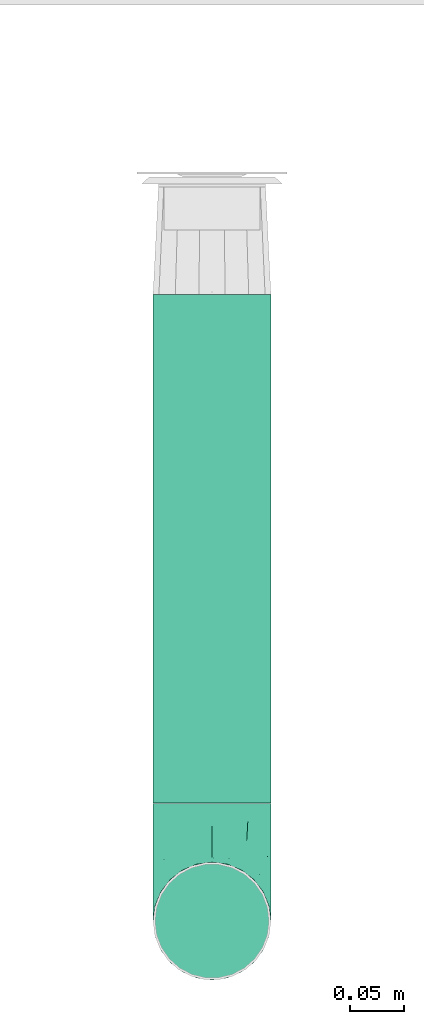
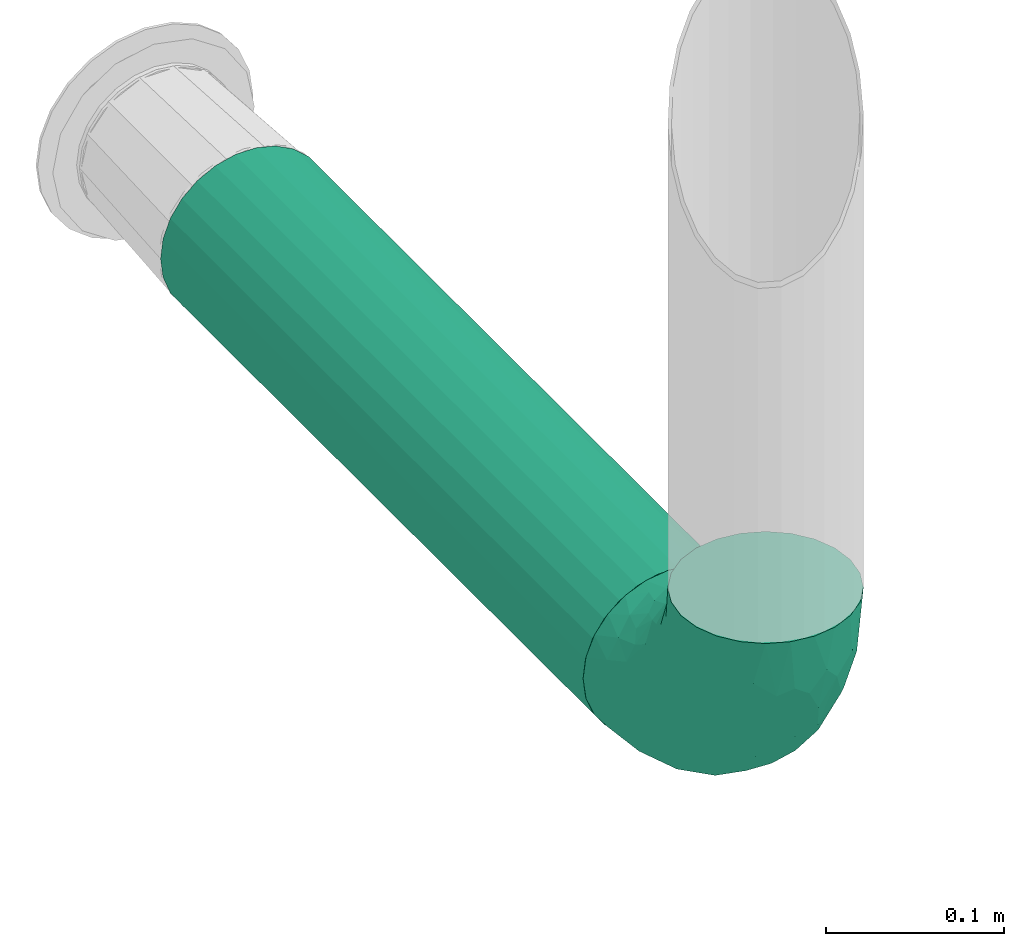
# One storey, part 72 of 123: 1 flow fitting, 1 flow segment.
"""IFC2X3 building model written with IfcOpenShell, lengths in millimetres."""

from ifc_helpers import new_model, entity, si_unit, converted_unit, derived_unit, direction, frame, origin_with_axes, origin_2d_with_axis, place, context, subcontext, project, spatial, hollow_circle, extrude, open_shell, surface_model, source, transform, mapped, material, layer, layer_set, layer_usage, type_object, element, save


model = new_model("IFC2X3")

# Units and contexts
model_context = context("Model", 3, precision=1e-05, world=origin_with_axes(), true_north=direction((0.0, 1.0)))
body_context = subcontext(model_context, "Body", "Model", "MODEL_VIEW")
ifc_project = project(units=[si_unit("AREAUNIT", "SQUARE_METRE"), si_unit("VOLUMEUNIT", "CUBIC_METRE", prefix="DECI"), si_unit("TIMEUNIT", "SECOND"), si_unit("THERMODYNAMICTEMPERATUREUNIT", "DEGREE_CELSIUS"), si_unit("PRESSUREUNIT", "PASCAL"), si_unit("MASSUNIT", "GRAM", prefix="KILO"), si_unit("LENGTHUNIT", "METRE", prefix="MILLI"), si_unit("POWERUNIT", "WATT"), si_unit("ELECTRICCURRENTUNIT", "AMPERE"), si_unit("ELECTRICVOLTAGEUNIT", "VOLT"), derived_unit("VOLUMETRICFLOWRATEUNIT", [(si_unit("VOLUMEUNIT", "CUBIC_METRE", prefix="DECI"), 1), (si_unit("TIMEUNIT", "SECOND"), -1)]), derived_unit("LINEARVELOCITYUNIT", [(si_unit("LENGTHUNIT", "METRE"), 1), (si_unit("TIMEUNIT", "SECOND"), -1)]), derived_unit("MASSDENSITYUNIT", [(si_unit("MASSUNIT", "GRAM", prefix="KILO"), 1), (si_unit("VOLUMEUNIT", "CUBIC_METRE"), -1)]), converted_unit("PLANEANGLEUNIT", "DEGREE", entity("IfcRatioMeasure", 0.01745), si_unit("PLANEANGLEUNIT", "RADIAN"), dimensions=[0, 0, 0, 0, 0, 0, 0])], contexts=[model_context])

# Site, building, storey
site_placement = place(None, origin_with_axes())
site = spatial("IfcSite", under=ifc_project, at=site_placement, CompositionType="ELEMENT")
building_placement = place(site_placement, origin_with_axes())
building = spatial("IfcBuilding", under=site, at=building_placement, Name="mc-building", CompositionType="ELEMENT")
storey_placement = place(building_placement, origin_with_axes())
storey = spatial("IfcBuildingStorey", under=building, at=storey_placement, Name="1. Korrus", CompositionType="ELEMENT", Elevation=0.0)

# Flow fitting
duct_fitting_type = type_object("IfcDuctFittingType", Name="BU", PredefinedType="BEND")
shared_shape_1 = source(origin_with_axes(), body_context, "Body", "SurfaceModel", [
    surface_model("IfcShellBasedSurfaceModel", [(-110.0, -38.89087, -38.89087), (-110.0, -55.0, 0.0), (-110.0, -27.5, -47.63139), (-110.0, -53.12592, -14.23505), (-110.0, -47.63139, -27.5), (-110.0, 47.63139, -27.5), (-110.0, 53.12592, 14.23505), (-110.0, 53.12592, -14.23505), (-110.0, -14.23505, -53.12592), (-110.0, 0.0, -55.0), (-110.0, 38.89087, -38.89087), (-110.0, 27.5, -47.63139), (-110.0, 14.23505, -53.12592), (-110.0, 55.0, 0.0), (-110.0, -53.12592, 14.23505), (-110.0, -47.63139, 27.5), (-110.0, -38.89087, 38.89087), (-110.0, 0.0, 55.0), (-110.0, -27.5, 47.63139), (-110.0, -14.23505, 53.12592), (-110.0, 38.89087, 38.89087), (-110.0, 47.63139, 27.5), (-110.0, 27.5, 47.63139), (-110.0, 14.23505, 53.12592), (0.0, -110.0, -55.0), (14.23505, -110.0, -53.12592), (-14.23505, -110.0, -53.12592), (-53.12592, -110.0, 14.23505), (-27.5, -110.0, -47.63139), (-47.63139, -110.0, -27.5), (-38.89087, -110.0, -38.89087), (55.0, -110.0, 0.0), (53.12592, -110.0, 14.23505), (38.89087, -110.0, -38.89087), (27.5, -110.0, -47.63139), (53.12592, -110.0, -14.23505), (47.63139, -110.0, -27.5), (-53.12592, -110.0, -14.23505), (-47.63139, -110.0, 27.5), (-38.89087, -110.0, 38.89087), (14.23505, -110.0, 53.12592), (-27.5, -110.0, 47.63139), (-14.23505, -110.0, 53.12592), (47.63139, -110.0, 27.5), (38.89087, -110.0, 38.89087), (27.5, -110.0, 47.63139), (0.0, -110.0, 55.0), (-55.0, -110.0, 0.0), (-60.44912, -32.56953, 51.94617), (-76.6405, -38.18013, 45.55988), (-64.21732, -48.68956, 43.63444), (-90.15553, -11.94394, 54.09138), (-76.00813, -5.38378, 55.0), (-70.18771, -18.55163, 54.03432), (-78.5998, -26.77405, 50.81338), (-93.27622, -45.77614, 33.48188), (-75.55424, -54.2118, 32.41257), (-96.12334, -22.13664, 50.81337), (-32.04182, -59.64019, 52.24446), (-18.36258, -70.48427, 54.04484), (-21.00813, -45.34362, 55.0), (-63.60674, -66.07878, 29.97482), (-74.66383, -63.08407, 19.92123), (-63.88653, -74.77858, 17.99134), (-93.11138, -56.59448, 10.50359), (-99.597, -52.72185, 18.52927), (-98.21577, -57.34403, 0.0), (-53.42855, -92.60092, 21.04759), (-88.54852, -54.8376, 21.04759), (-5.38378, -76.00813, 55.0), (-11.86161, -90.23965, 54.10313), (-56.64619, -93.12774, 10.22088), (-57.34403, -98.21577, 0.0), (-44.60838, -44.60838, 52.13415), (-45.34362, -21.00813, 55.0), (-92.68484, -35.46673, 43.63443), (-22.25266, -95.40765, 50.81337), (-27.23711, -77.39884, 50.81337), (-43.70931, -69.58671, 44.47149), (-35.97783, -90.61597, 43.63443), (-58.67786, -84.31125, 16.04456), (-57.2828, -79.3123, 24.9774), (-82.93277, -60.36161, 12.91784), (-49.88337, -54.51816, 47.224), (-74.57753, -66.83759, 9.55742), (-45.35812, -94.97281, 33.48188), (-59.18663, -88.95241, 0.0), (-51.517, -78.6292, 33.48188), (-65.14788, -80.03077, 0.0), (-56.45322, -62.06476, 39.63545), (-88.95241, -59.18663, 0.0), (-80.03077, -65.14788, 0.0), (-71.10913, -71.10913, 0.0), (-94.9309, -45.36788, -33.48188), (-93.11358, -56.60141, -10.46614), (-99.64997, -52.79499, -18.30015), (-79.99933, -46.56772, -37.92748), (-90.20425, -36.08686, -43.63443), (-45.34362, -21.00813, -55.0), (-72.75364, -19.68651, -53.60527), (-76.00813, -5.38378, -55.0), (-21.00813, -45.34362, -55.0), (-5.38378, -76.00813, -55.0), (-21.91957, -65.12078, -53.85897), (-35.41876, -92.89265, -43.63443), (-91.10309, -11.02766, -54.21832), (-45.77614, -93.27622, -33.48188), (-90.50474, -23.21022, -50.81337), (-70.92854, -33.31794, -49.51754), (-78.52933, -63.35627, -11.73997), (-24.91508, -84.05606, -50.81337), (-88.78941, -54.74452, -21.04759), (-63.49062, -67.59111, -28.46929), (-73.36422, -62.46673, -22.94182), (-69.59921, -57.34866, -33.48187), (-56.59448, -93.11138, -10.50359), (-54.10679, -75.85581, -32.31867), (-54.8376, -88.54852, -21.04759), (-57.75956, -31.09612, -52.80882), (-52.72185, -99.597, -18.52927), (-12.62913, -89.46304, -53.99097), (-34.46825, -66.46123, -50.04329), (-43.9837, -43.9837, -52.42279), (-65.78527, -72.58348, -17.68796), (-57.47001, -51.99467, -44.91465), (-70.34468, -43.65295, -44.21951), (-60.72547, -82.29174, -12.88567), (-42.34915, -74.24548, -43.63444), (-57.25194, -63.5016, -38.08211), (-80.95344, -53.56991, -29.32027), (-52.32891, -4.55257, -54.0482), (14.95561, -36.05775, -42.26543), (14.88266, -20.92917, -33.7947), (32.52942, -47.13398, -30.48571), (19.3559, -65.35825, -48.00507), (30.24048, -70.09027, -41.7461), (-28.49299, 30.5778, -16.4009), (-47.13398, 32.52942, -30.48571), (-70.35075, 46.44478, -19.5952), (-22.4954, -22.4954, -53.25347), (-4.55257, -52.32891, -54.0482), (-75.47368, 11.22546, -52.60718), (-81.32209, 51.5606, -9.98467), (-70.09027, 30.24048, -41.7461), (-80.81763, 41.84862, -32.14655), (-9.15831, 10.852, -27.8997), (-36.05774, 14.95561, -42.26543), (-65.35825, 19.3559, -48.00507), (3.94376, -43.9333, -50.53315), (11.22546, -75.47368, -52.60718), (-43.9333, 3.94376, -50.53315), (-13.39742, -13.39743, -48.13058), (50.20582, -74.51695, -9.9731), (41.8609, -47.82256, -9.92641), (49.37776, -67.29486, 0.0), (18.93131, -11.7156, -17.56239), (-1.23348, 12.25375, -12.18106), (-27.5, 32.89419, 0.0), (41.84862, -80.81763, -32.14655), (46.44478, -70.35075, -19.5952), (35.70604, -41.31408, -20.38235), (6.67262, 6.67262, 0.0), (32.89419, -27.5, 0.0), (-50.36265, 42.95545, -9.51562), (-67.29486, 49.37776, 0.0), (-5.47251, -5.47251, -39.92906), (-70.35075, 46.44478, 19.5952), (-74.51695, 50.20582, 9.9731), (-47.13398, 32.52942, 30.48571), (-41.31407, 35.70604, 20.38235), (-80.81763, 41.84862, 32.14655), (11.22546, -75.47368, 52.60718), (-4.55257, -52.32891, 54.0482), (-36.05774, 14.95561, 42.26543), (-65.35825, 19.3559, 48.00507), (-43.9333, 3.94376, 50.53315), (-70.09027, 30.24048, 41.7461), (-11.7156, 18.93131, 17.56239), (12.25375, -1.23348, 12.18106), (30.5778, -28.49299, 16.4009), (42.95545, -50.36265, 9.51562), (51.5606, -81.32209, 9.98467), (-52.32891, -4.55257, 54.0482), (-75.47368, 11.22546, 52.60718), (-13.39742, -13.39743, 48.13058), (-22.4954, -22.4954, 53.25347), (3.94376, -43.9333, 50.53315), (-20.92916, 14.88266, 33.79469), (10.852, -9.15831, 27.8997), (-47.82256, 41.8609, 9.92641), (32.52942, -47.13398, 30.48571), (46.44478, -70.35075, 19.5952), (41.84862, -80.81763, 32.14655), (14.95561, -36.05775, 42.26543), (19.3559, -65.35825, 48.00507), (30.24048, -70.09027, 41.7461), (-5.47251, -5.47251, 39.92906)], [open_shell([[[0, 1, 2]], [[3, 1, 4]], [[5, 6, 7]], [[8, 1, 9]], [[2, 1, 8]], [[4, 1, 0]], [[10, 9, 6]], [[9, 10, 11]], [[11, 12, 9]], [[6, 5, 10]], [[7, 6, 13]], [[14, 15, 9]], [[9, 15, 16]], [[17, 16, 18]], [[9, 16, 17]], [[19, 17, 18]], [[9, 20, 21]], [[6, 9, 21]], [[9, 22, 20]], [[23, 22, 9]], [[17, 23, 9]], [[9, 1, 14]], [[24, 25, 26]], [[26, 27, 28]], [[29, 30, 27]], [[28, 27, 30]], [[26, 31, 32]], [[33, 31, 34]], [[25, 34, 31]], [[35, 31, 36]], [[33, 36, 31]], [[31, 26, 25]], [[29, 27, 37]], [[38, 27, 26]], [[39, 38, 26]], [[40, 41, 26]], [[41, 39, 26]], [[40, 42, 41]], [[43, 44, 26]], [[43, 26, 32]], [[44, 45, 26]], [[26, 45, 40]], [[40, 46, 42]], [[47, 37, 27]], [[48, 49, 50]], [[51, 52, 17]], [[48, 53, 54]], [[49, 55, 56]], [[16, 15, 55]], [[18, 57, 19]], [[58, 59, 60]], [[61, 62, 63]], [[64, 65, 14]], [[53, 51, 54]], [[66, 64, 14]], [[27, 38, 67]], [[65, 68, 55]], [[68, 65, 64]], [[69, 59, 70]], [[71, 72, 27]], [[73, 60, 74]], [[55, 49, 75]], [[42, 70, 76]], [[51, 57, 54]], [[77, 78, 79]], [[42, 76, 41]], [[46, 70, 42]], [[55, 68, 56]], [[75, 18, 16]], [[77, 79, 76]], [[80, 67, 81]], [[68, 82, 62]], [[83, 78, 58]], [[82, 84, 62]], [[39, 79, 85]], [[71, 67, 80]], [[72, 71, 86]], [[67, 85, 87]], [[88, 80, 63]], [[39, 41, 79]], [[87, 79, 78]], [[55, 75, 16]], [[50, 89, 83]], [[38, 39, 85]], [[56, 68, 62]], [[61, 87, 89]], [[48, 50, 83]], [[18, 75, 57]], [[54, 75, 49]], [[38, 85, 67]], [[85, 79, 87]], [[56, 62, 61]], [[50, 56, 89]], [[87, 61, 81]], [[90, 64, 66]], [[14, 1, 66]], [[91, 92, 84]], [[82, 90, 91]], [[90, 82, 64]], [[62, 84, 63]], [[84, 82, 91]], [[64, 82, 68]], [[65, 15, 14]], [[15, 65, 55]], [[72, 47, 27]], [[86, 71, 80]], [[67, 71, 27]], [[88, 63, 92]], [[63, 80, 81]], [[63, 81, 61]], [[87, 81, 67]], [[41, 76, 79]], [[70, 59, 77]], [[76, 70, 77]], [[69, 70, 46]], [[77, 59, 58]], [[59, 69, 60]], [[77, 58, 78]], [[73, 58, 60]], [[19, 57, 51]], [[54, 57, 75]], [[19, 51, 17]], [[53, 52, 51]], [[53, 74, 52]], [[73, 74, 48]], [[53, 48, 74]], [[83, 73, 48]], [[73, 83, 58]], [[78, 83, 89]], [[78, 89, 87]], [[61, 89, 56]], [[54, 49, 48]], [[50, 49, 56]], [[88, 86, 80]], [[63, 84, 92]], [[93, 4, 0]], [[66, 94, 90]], [[95, 94, 3]], [[96, 93, 97]], [[98, 99, 100]], [[0, 2, 97]], [[101, 102, 103]], [[104, 28, 30]], [[9, 105, 8]], [[30, 106, 104]], [[107, 105, 99]], [[97, 107, 108]], [[94, 109, 90]], [[2, 8, 107]], [[94, 66, 3]], [[110, 26, 28]], [[94, 111, 109]], [[112, 113, 114]], [[72, 115, 37]], [[116, 106, 117]], [[98, 118, 99]], [[119, 115, 117]], [[115, 119, 37]], [[110, 120, 26]], [[103, 110, 121]], [[117, 106, 119]], [[120, 110, 103]], [[98, 101, 122]], [[117, 123, 116]], [[108, 124, 125]], [[126, 117, 115]], [[30, 29, 106]], [[120, 102, 24]], [[110, 104, 127]], [[97, 125, 96]], [[118, 122, 124]], [[124, 127, 128]], [[93, 0, 97]], [[86, 126, 115]], [[127, 106, 116]], [[129, 113, 111]], [[4, 93, 95]], [[114, 129, 96]], [[28, 104, 110]], [[127, 104, 106]], [[2, 107, 97]], [[108, 107, 99]], [[118, 108, 99]], [[100, 99, 105]], [[128, 112, 114]], [[127, 124, 121]], [[66, 1, 3]], [[91, 90, 109]], [[95, 111, 94]], [[109, 123, 92]], [[114, 113, 129]], [[111, 95, 93]], [[95, 3, 4]], [[86, 115, 72]], [[37, 47, 72]], [[88, 92, 123]], [[123, 117, 126]], [[126, 88, 123]], [[88, 126, 86]], [[119, 29, 37]], [[29, 119, 106]], [[111, 93, 129]], [[124, 114, 125]], [[100, 105, 9]], [[8, 105, 107]], [[108, 118, 124]], [[122, 118, 98]], [[96, 129, 93]], [[109, 111, 113]], [[113, 123, 109]], [[116, 123, 112]], [[113, 112, 123]], [[116, 112, 128]], [[116, 128, 127]], [[124, 128, 114]], [[103, 122, 101]], [[127, 121, 110]], [[121, 122, 103]], [[122, 121, 124]], [[26, 120, 24]], [[102, 120, 103]], [[108, 125, 97]], [[109, 92, 91]], [[96, 125, 114]], [[100, 130, 98]], [[131, 132, 133]], [[134, 135, 34]], [[136, 137, 138]], [[101, 139, 140]], [[9, 141, 100]], [[138, 7, 142]], [[137, 143, 144]], [[142, 7, 13]], [[145, 146, 137]], [[146, 147, 143]], [[5, 138, 144]], [[7, 138, 5]], [[5, 144, 10]], [[140, 148, 149]], [[143, 11, 10]], [[147, 12, 11]], [[100, 141, 130]], [[98, 139, 101]], [[148, 134, 149]], [[139, 150, 151]], [[152, 153, 154]], [[150, 139, 130]], [[25, 24, 149]], [[141, 12, 147]], [[132, 145, 155]], [[156, 136, 157]], [[158, 33, 135]], [[148, 139, 151]], [[36, 33, 158]], [[34, 135, 33]], [[159, 160, 153]], [[160, 159, 133]], [[137, 146, 143]], [[152, 154, 31]], [[137, 136, 145]], [[161, 162, 155]], [[133, 159, 158]], [[134, 148, 131]], [[163, 164, 157]], [[163, 142, 164]], [[102, 101, 140]], [[162, 154, 153]], [[159, 35, 36]], [[155, 156, 161]], [[131, 165, 132]], [[155, 145, 156]], [[98, 130, 139]], [[150, 130, 141]], [[147, 150, 141]], [[9, 12, 141]], [[149, 24, 102]], [[148, 140, 139]], [[140, 149, 102]], [[34, 25, 134]], [[146, 151, 150]], [[143, 147, 11]], [[147, 146, 150]], [[145, 165, 146]], [[25, 149, 134]], [[135, 134, 131]], [[135, 131, 133]], [[151, 165, 131]], [[148, 151, 131]], [[165, 151, 146]], [[160, 133, 132]], [[132, 165, 145]], [[36, 158, 159]], [[133, 158, 135]], [[10, 144, 143]], [[137, 144, 138]], [[162, 153, 155]], [[159, 153, 152]], [[160, 155, 153]], [[155, 160, 132]], [[152, 35, 159]], [[35, 152, 31]], [[136, 138, 163]], [[164, 142, 13]], [[142, 163, 138]], [[136, 163, 157]], [[161, 156, 157]], [[136, 156, 145]], [[166, 6, 21]], [[167, 164, 13]], [[166, 168, 169]], [[170, 168, 166]], [[69, 171, 172]], [[173, 174, 175]], [[174, 176, 22]], [[161, 157, 177]], [[170, 20, 176]], [[21, 20, 170]], [[178, 179, 162]], [[180, 181, 154]], [[182, 175, 183]], [[183, 23, 17]], [[184, 185, 186]], [[74, 185, 182]], [[52, 74, 182]], [[187, 188, 177]], [[166, 169, 189]], [[190, 179, 188]], [[22, 176, 20]], [[180, 154, 162]], [[32, 191, 43]], [[192, 44, 43]], [[43, 191, 192]], [[32, 31, 181]], [[193, 194, 195]], [[194, 40, 45]], [[190, 193, 195]], [[45, 44, 195]], [[69, 46, 171]], [[74, 60, 185]], [[157, 164, 189]], [[167, 189, 164]], [[172, 60, 69]], [[185, 172, 186]], [[173, 187, 168]], [[191, 32, 181]], [[190, 195, 192]], [[179, 190, 191]], [[175, 174, 183]], [[171, 40, 194]], [[188, 193, 190]], [[175, 185, 184]], [[177, 178, 161]], [[173, 196, 187]], [[177, 188, 178]], [[60, 172, 185]], [[186, 172, 171]], [[194, 186, 171]], [[46, 40, 171]], [[183, 17, 52]], [[175, 182, 185]], [[182, 183, 52]], [[22, 23, 174]], [[193, 184, 186]], [[195, 194, 45]], [[194, 193, 186]], [[188, 196, 193]], [[23, 183, 174]], [[176, 174, 173]], [[176, 173, 168]], [[184, 196, 173]], [[175, 184, 173]], [[196, 184, 193]], [[169, 168, 187]], [[187, 196, 188]], [[21, 170, 166]], [[168, 170, 176]], [[44, 192, 195]], [[190, 192, 191]], [[157, 189, 177]], [[166, 189, 167]], [[169, 177, 189]], [[177, 169, 187]], [[167, 6, 166]], [[6, 167, 13]], [[179, 191, 180]], [[154, 181, 31]], [[181, 180, 191]], [[179, 180, 162]], [[161, 178, 162]], [[179, 178, 188]]])]),
])
flow_fitting_placement = place(storey_placement, frame((27194.49649, -687.64676, 2300.0), z_axis=(1.0, 0.0, 0.0), x_axis=(0.0, -1.0, 0.0)))
element("IfcFlowFitting", 1, at=flow_fitting_placement, inside=storey, type_object=duct_fitting_type, Name="BU", context=body_context, shape_type="MappedRepresentation", body=[
    mapped(shared_shape_1, transform((0.0, 0.0, 0.0), scale=1.0)),
])

# Flow segment
ifc_material = material(Name="FZ1")
ifc_layer = layer(ifc_material, 0.0)
ifc_layer_set = layer_set([ifc_layer], Name="FZ1")
ifc_layer_usage = layer_usage(ifc_layer_set, "AXIS1", "POSITIVE", 0.0)
duct_segment_type = type_object("IfcDuctSegmentType", PredefinedType="RIGIDSEGMENT")
shared_shape_2 = source(origin_with_axes(), body_context, "Body", "SweptSolid", [
    extrude(hollow_circle(Radius=55.0, WallThickness=2.0, at=origin_2d_with_axis()), frame((0.0, 0.0, 0.0), z_axis=(1.0, 0.0, 0.0), x_axis=(0.0, 1.0, 0.0)), (0.0, 0.0, 1.0), 475.2),
])
flow_segment_placement = place(storey_placement, frame((27194.49649, -102.39828, 2300.0), z_axis=(0.0, 0.0, 1.0), x_axis=(0.0, -1.0, 0.0)))
element("IfcFlowSegment", 2, at=flow_segment_placement, inside=storey, type_object=duct_segment_type, material=ifc_layer_usage, context=body_context, shape_type="MappedRepresentation", body=[
    mapped(shared_shape_2, transform((0.0, 0.0, 0.0), scale=1.0)),
])

save(model, "model.ifc")
